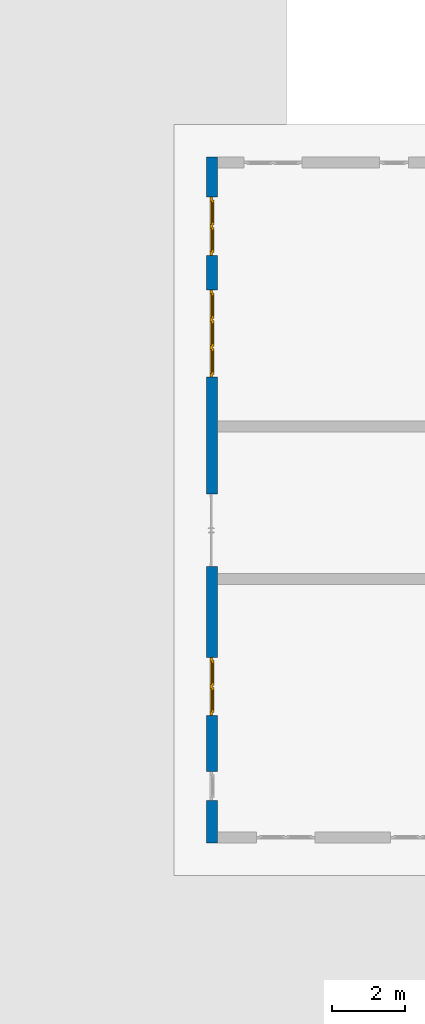
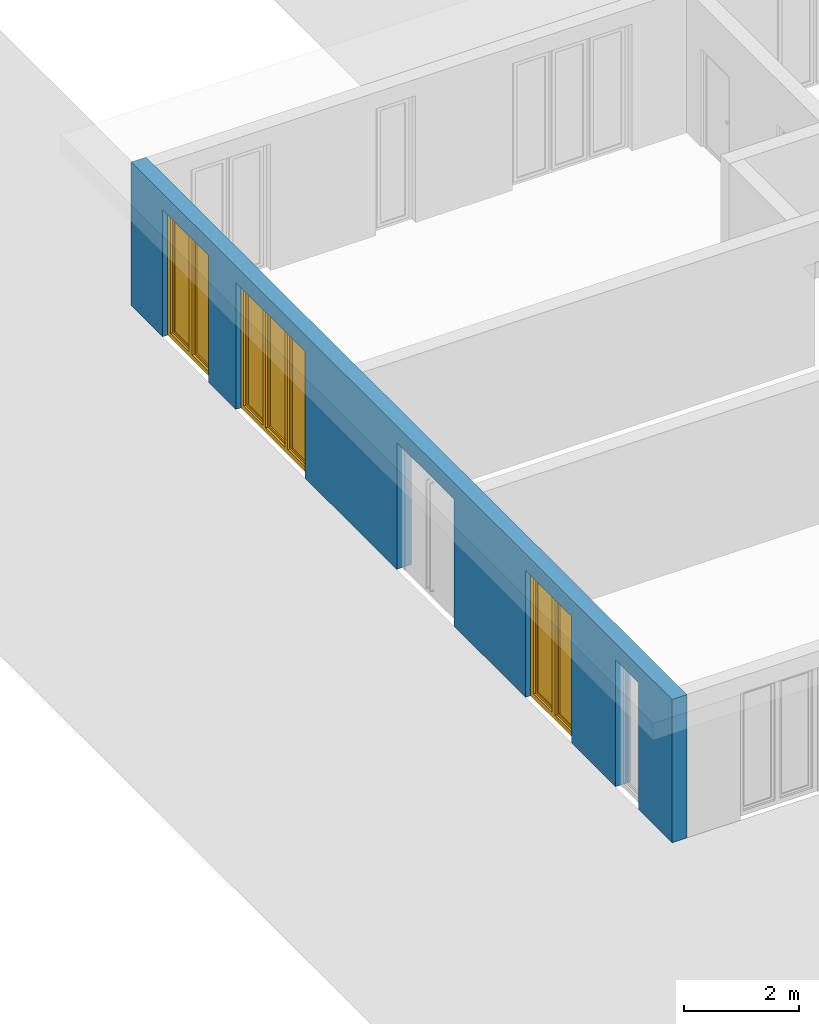
# One storey, part 9 of 23: 3 windows, 1 wall, 5 openings.
"""IFC4 building model written with IfcOpenShell, lengths in metres."""

from ifc_helpers import new_model, entity, si_unit, converted_unit, derived_unit, direction, frame, origin_with_axes, place, context, subcontext, project, spatial, polygons, source, transform, mapped, material, type_object, element, fill, save


model = new_model("IFC4")

# Units and contexts
model_context = context("Model", 3, precision=1e-05, world=origin_with_axes(), true_north=direction((0.0, 1.0)))
body_context = subcontext(model_context, "Body", "Model", "MODEL_VIEW")
ifc_project = project(units=[si_unit("LENGTHUNIT", "METRE"), si_unit("AREAUNIT", "SQUARE_METRE"), si_unit("VOLUMEUNIT", "CUBIC_METRE"), converted_unit("PLANEANGLEUNIT", "DEGREE", entity("IfcPlaneAngleMeasure", 0.0174532925199), si_unit("PLANEANGLEUNIT", "RADIAN"), dimensions=[0, 0, 0, 0, 0, 0, 0]), converted_unit("TIMEUNIT", "Year", entity("IfcTimeMeasure", 31556926.0), si_unit("TIMEUNIT", "SECOND"), dimensions=[0, 0, 1, 0, 0, 0, 0]), si_unit("MASSUNIT", "GRAM", prefix="KILO"), si_unit("THERMODYNAMICTEMPERATUREUNIT", "DEGREE_CELSIUS"), si_unit("LUMINOUSINTENSITYUNIT", "LUMEN"), si_unit("ENERGYUNIT", "JOULE", prefix="MEGA"), derived_unit("THERMALCONDUCTANCEUNIT", [(si_unit("POWERUNIT", "WATT"), 1), (si_unit("LENGTHUNIT", "METRE"), -1), (si_unit("THERMODYNAMICTEMPERATUREUNIT", "KELVIN"), -1)]), derived_unit("SPECIFICHEATCAPACITYUNIT", [(si_unit("ENERGYUNIT", "JOULE"), 1), (si_unit("MASSUNIT", "GRAM", prefix="KILO"), -1), (si_unit("THERMODYNAMICTEMPERATUREUNIT", "KELVIN"), -1)]), derived_unit("MASSDENSITYUNIT", [(si_unit("MASSUNIT", "GRAM", prefix="KILO"), 1), (si_unit("VOLUMEUNIT", "CUBIC_METRE"), -1)])], contexts=[model_context])

# Site, building, storey
site_placement = place(None, origin_with_axes())
site = spatial("IfcSite", under=ifc_project, at=site_placement, CompositionType="ELEMENT")
building_placement = place(site_placement, origin_with_axes())
building = spatial("IfcBuilding", under=site, at=building_placement, CompositionType="ELEMENT")
storey_placement = place(building_placement, origin_with_axes())
storey = spatial("IfcBuildingStorey", under=building, at=storey_placement, Name="0. Geschoss", CompositionType="ELEMENT", Elevation=0.0)

# Wall, openings, windows
ifc_material = material()
wall_type = type_object("IfcWallType", Name="300", PredefinedType="NOTDEFINED")
wall_placement = place(storey_placement, frame((-11.7421993804, -9.92881223104, 0.0), z_axis=(0.0, 0.0, 1.0), x_axis=(0.0, 1.0, 0.0)))
wall = element("IfcWall", 1, at=wall_placement, inside=storey, type_object=wall_type, material=ifc_material, Name="Wand-001", PredefinedType="NOTDEFINED", context=body_context, shape_type="Tessellation", body=[
    polygons([(7.5921181063, -0.3, 0.0), (7.5921181063, -0.3, 2.7), (9.5921181063, -0.3, 2.7), (9.5921181063, -0.3, 0.0), (12.8, -0.3, 0.0), (12.8, -0.3, 2.7), (15.2, -0.3, 2.7), (15.2, -0.3, 0.0), (16.15, -0.3, 0.0), (16.15, -0.3, 2.7), (17.75, -0.3, 2.7), (17.75, -0.3, 0.0), (18.85, -0.3, 0.0), (18.85, -0.3, 3.05), (0.0, -0.3, 3.05), (0.0, -0.3, 0.0), (1.16441876325, -0.3, 0.0), (1.16441876325, -0.3, 2.7), (1.96441876325, -0.3, 2.7), (1.96441876325, -0.3, 0.0), (3.5, -0.3, 0.0), (3.5, -0.3, 2.7), (5.1, -0.3, 2.7), (5.1, -0.3, 0.0), (7.5921181063, -0.1, 0.0), (7.5921181063, -0.1, 2.7), (9.5921181063, -0.1, 2.7), (9.5921181063, -0.1, 0.0), (9.5921181063, 0.0, 0.0), (12.8, 0.0, 0.0), (12.8, -0.1, 0.0), (12.8, -0.1, 2.7), (15.2, -0.1, 2.7), (15.2, -0.1, 0.0), (15.2, 0.0, 0.0), (16.15, 0.0, 0.0), (16.15, -0.1, 0.0), (16.15, -0.1, 2.7), (17.75, -0.1, 2.7), (17.75, -0.1, 0.0), (17.75, 0.0, 0.0), (18.85, 0.0, 0.0), (18.85, 0.0, 3.05), (0.0, 0.0, 3.05), (0.0, 0.0, 0.0), (1.16441876325, 0.0, 0.0), (1.16441876325, -0.1, 0.0), (1.16441876325, -0.1, 2.7), (1.96441876325, -0.1, 2.7), (1.96441876325, -0.1, 0.0), (1.96441876325, 0.0, 0.0), (3.5, 0.0, 0.0), (3.5, -0.1, 0.0), (3.5, -0.1, 2.7), (5.1, -0.1, 2.7), (5.1, -0.1, 0.0), (5.1, 0.0, 0.0), (7.5921181063, 0.0, 0.0), (7.5921181063, 0.0, 2.7), (9.5921181063, 0.0, 2.7), (5.1, 0.0, 2.7), (3.5, 0.0, 2.7), (1.96441876325, 0.0, 2.7), (1.16441876325, 0.0, 2.7), (17.75, 0.0, 2.7), (16.15, 0.0, 2.7), (15.2, 0.0, 2.7), (12.8, 0.0, 2.7)], [[[1, 2, 3, 4, 5, 6, 7, 8, 9, 10, 11, 12, 13, 14, 15, 16, 17, 18, 19, 20, 21, 22, 23, 24]], [[2, 1, 25, 26]], [[3, 2, 26, 27]], [[4, 3, 27, 28]], [[4, 28, 29, 30, 31, 5]], [[31, 32, 6, 5]], [[32, 33, 7, 6]], [[33, 34, 8, 7]], [[8, 34, 35, 36, 37, 9]], [[10, 9, 37, 38]], [[11, 10, 38, 39]], [[12, 11, 39, 40]], [[40, 41, 42, 13, 12]], [[14, 13, 42, 43]], [[14, 43, 44, 15]], [[44, 45, 16, 15]], [[46, 47, 17, 16, 45]], [[47, 48, 18, 17]], [[48, 49, 19, 18]], [[49, 50, 20, 19]], [[20, 50, 51, 52, 53, 21]], [[22, 21, 53, 54]], [[23, 22, 54, 55]], [[24, 23, 55, 56]], [[25, 1, 24, 56, 57, 58]], [[26, 25, 58, 59]], [[27, 26, 59, 60]], [[28, 27, 60, 29]], [[30, 29, 60, 59, 58, 57, 61, 62, 52, 51, 63, 64, 46, 45, 44, 43, 42, 41, 65, 66, 36, 35, 67, 68]], [[30, 68, 32, 31]], [[68, 67, 33, 32]], [[67, 35, 34, 33]], [[38, 37, 36, 66]], [[39, 38, 66, 65]], [[40, 39, 65, 41]], [[46, 64, 48, 47]], [[64, 63, 49, 48]], [[63, 51, 50, 49]], [[54, 53, 52, 62]], [[55, 54, 62, 61]], [[56, 55, 61, 57]]], closed=True),
])
opening_1_placement = place(wall_placement, frame((16.95, 0.0, 0.0), z_axis=(0.0, 0.0, 1.0), x_axis=(1.0, 0.0, 0.0)))
opening_1 = element("IfcOpeningElement", 2, at=opening_1_placement, cuts=wall, Name="Fenster-001", context=body_context, identifier="Reference", shape_type="Tessellation", body=[
    polygons([(-0.8, -0.1, 0.0), (-0.8, -0.1, 2.7), (-0.8, 0.000999999999999, 2.7), (-0.8, 0.000999999999999, 0.0), (-0.8, -0.301, 0.0), (-0.8, -0.301, 2.7), (0.8, -0.1, 2.7), (0.8, 0.000999999999999, 2.7), (0.8, -0.301, 2.7), (0.8, 0.000999999999999, 0.0), (0.8, -0.1, 0.0), (0.8, -0.301, 0.0)], [[[1, 2, 3, 4]], [[2, 1, 5, 6]], [[7, 8, 3, 2, 6, 9]], [[8, 10, 4, 3]], [[1, 4, 10, 11, 12, 5]], [[6, 5, 12, 9]], [[7, 11, 10, 8]], [[11, 7, 9, 12]]], closed=True),
])
opening_2_placement = place(wall_placement, frame((14.0, 0.0, 0.0), z_axis=(0.0, 0.0, 1.0), x_axis=(1.0, 0.0, 0.0)))
opening_2 = element("IfcOpeningElement", 3, at=opening_2_placement, cuts=wall, Name="Fenster-002", context=body_context, identifier="Reference", shape_type="Tessellation", body=[
    polygons([(-1.2, -0.1, 0.0), (-1.2, -0.1, 2.7), (-1.2, 0.000999999999999, 2.7), (-1.2, 0.000999999999999, 0.0), (-1.2, -0.301, 0.0), (-1.2, -0.301, 2.7), (1.2, -0.1, 2.7), (1.2, 0.000999999999999, 2.7), (1.2, -0.301, 2.7), (1.2, 0.000999999999999, 0.0), (1.2, -0.1, 0.0), (1.2, -0.301, 0.0)], [[[1, 2, 3, 4]], [[2, 1, 5, 6]], [[7, 8, 3, 2, 6, 9]], [[8, 10, 4, 3]], [[1, 4, 10, 11, 12, 5]], [[6, 5, 12, 9]], [[7, 11, 10, 8]], [[11, 7, 9, 12]]], closed=True),
])
opening_3_placement = place(wall_placement, frame((4.3, 0.0, 0.0), z_axis=(0.0, 0.0, 1.0), x_axis=(1.0, 0.0, 0.0)))
opening_3 = element("IfcOpeningElement", 4, at=opening_3_placement, cuts=wall, Name="Fenster-001", context=body_context, identifier="Reference", shape_type="Tessellation", body=[
    polygons([(-0.8, -0.1, 0.0), (-0.8, -0.1, 2.7), (-0.8, 0.000999999999999, 2.7), (-0.8, 0.000999999999999, 0.0), (-0.8, -0.301, 0.0), (-0.8, -0.301, 2.7), (0.8, -0.1, 2.7), (0.8, 0.000999999999999, 2.7), (0.8, -0.301, 2.7), (0.8, 0.000999999999999, 0.0), (0.8, -0.1, 0.0), (0.8, -0.301, 0.0)], [[[1, 2, 3, 4]], [[2, 1, 5, 6]], [[7, 8, 3, 2, 6, 9]], [[8, 10, 4, 3]], [[1, 4, 10, 11, 12, 5]], [[6, 5, 12, 9]], [[7, 11, 10, 8]], [[11, 7, 9, 12]]], closed=True),
])
opening_4_placement = place(wall_placement, frame((1.56441876325, 0.0, 0.0), z_axis=(0.0, 0.0, 1.0), x_axis=(1.0, 0.0, 0.0)))
element("IfcOpeningElement", 5, at=opening_4_placement, cuts=wall, Name="Fenster-003", context=body_context, identifier="Reference", shape_type="Tessellation", body=[
    polygons([(-0.4, -0.1, 0.0), (-0.4, -0.1, 2.7), (-0.4, 0.000999999999999, 2.7), (-0.4, 0.000999999999999, 0.0), (-0.4, -0.301, 0.0), (-0.4, -0.301, 2.7), (0.4, -0.1, 2.7), (0.4, 0.000999999999999, 2.7), (0.4, -0.301, 2.7), (0.4, 0.000999999999999, 0.0), (0.4, -0.1, 0.0), (0.4, -0.301, 0.0)], [[[1, 2, 3, 4]], [[2, 1, 5, 6]], [[7, 8, 3, 2, 6, 9]], [[8, 10, 4, 3]], [[1, 4, 10, 11, 12, 5]], [[6, 5, 12, 9]], [[7, 11, 10, 8]], [[11, 7, 9, 12]]], closed=True),
])
opening_5_placement = place(wall_placement, frame((8.5921181063, 0.0, 0.0), z_axis=(0.0, 0.0, 1.0), x_axis=(1.0, 0.0, 0.0)))
element("IfcOpeningElement", 6, at=opening_5_placement, cuts=wall, context=body_context, identifier="Reference", shape_type="Tessellation", body=[
    polygons([(-1.0, -0.1, 0.0), (-1.0, -0.1, 2.7), (-1.0, 0.000999999999999, 2.7), (-1.0, 0.000999999999999, 0.0), (-1.0, -0.301, 0.0), (-1.0, -0.301, 2.7), (1.0, -0.1, 2.7), (1.0, 0.000999999999999, 2.7), (1.0, -0.301, 2.7), (1.0, 0.000999999999999, 0.0), (1.0, -0.1, 0.0), (1.0, -0.301, 0.0)], [[[1, 2, 3, 4]], [[2, 1, 5, 6]], [[7, 8, 3, 2, 6, 9]], [[8, 10, 4, 3]], [[1, 4, 10, 11, 12, 5]], [[6, 5, 12, 9]], [[7, 11, 10, 8]], [[11, 7, 9, 12]]], closed=True),
])
window_type_1 = type_object("IfcWindowType", Name="2-1+1 26", PartitioningType="DOUBLE_PANEL_VERTICAL", PredefinedType="WINDOW")
shared_shape_1 = source(origin_with_axes(), body_context, "Body", "Tessellation", [
    polygons([(0.8, -0.07, 0.0), (0.7, -0.07, 0.1), (0.7, 0.0, 0.1), (0.8, 0.0, 0.0), (0.8, -0.07, 2.7), (0.7, -0.07, 2.6), (0.7, 0.0, 2.6), (0.8, 0.0, 2.7)], [[[1, 2, 3, 4]], [[1, 5, 6, 2]], [[2, 6, 7, 3]], [[4, 3, 7, 8]], [[5, 1, 4, 8]], [[6, 5, 8, 7]]], closed=True),
    polygons([(-0.8, -0.07, 0.0), (-0.8, -0.07, 2.7), (-0.8, 0.0, 2.7), (-0.8, 0.0, 0.0), (-0.7, -0.07, 0.1), (-0.7, -0.07, 2.6), (-0.7, 0.0, 2.6), (-0.7, 0.0, 0.1)], [[[1, 2, 3, 4]], [[1, 5, 6, 2]], [[2, 6, 7, 3]], [[4, 3, 7, 8]], [[5, 1, 4, 8]], [[6, 5, 8, 7]]], closed=True),
    polygons([(0.8, -0.07, 0.0), (-0.8, -0.07, 0.0), (-0.8, 0.0, 0.0), (0.8, 0.0, 0.0), (0.7, -0.07, 0.1), (0.05, -0.07, 0.1), (-0.05, -0.07, 0.1), (-0.7, -0.07, 0.1), (-0.7, 0.0, 0.1), (-0.05, 0.0, 0.1), (0.05, 0.0, 0.1), (0.7, 0.0, 0.1)], [[[1, 2, 3, 4]], [[1, 5, 6, 7, 8, 2]], [[2, 8, 9, 3]], [[4, 3, 9, 10, 11, 12]], [[5, 1, 4, 12]], [[6, 5, 12, 11]], [[7, 6, 11, 10]], [[8, 7, 10, 9]]], closed=True),
    polygons([(0.8, -0.07, 2.7), (0.7, -0.07, 2.6), (0.7, 0.0, 2.6), (0.8, 0.0, 2.7), (-0.8, -0.07, 2.7), (-0.7, -0.07, 2.6), (-0.05, -0.07, 2.6), (0.05, -0.07, 2.6), (0.05, 0.0, 2.6), (-0.05, 0.0, 2.6), (-0.7, 0.0, 2.6), (-0.8, 0.0, 2.7)], [[[1, 2, 3, 4]], [[1, 5, 6, 7, 8, 2]], [[2, 8, 9, 3]], [[4, 3, 9, 10, 11, 12]], [[5, 1, 4, 12]], [[6, 5, 12, 11]], [[7, 6, 11, 10]], [[8, 7, 10, 9]]], closed=True),
    polygons([(0.05, -0.07, 0.1), (-0.05, -0.07, 0.1), (-0.05, 0.0, 0.1), (0.05, 0.0, 0.1), (0.05, -0.07, 2.6), (-0.05, -0.07, 2.6), (-0.05, 0.0, 2.6), (0.05, 0.0, 2.6)], [[[1, 2, 3, 4]], [[1, 5, 6, 2]], [[2, 6, 7, 3]], [[4, 3, 7, 8]], [[5, 1, 4, 8]], [[6, 5, 8, 7]]], closed=True),
    polygons([(0.72, 0.0, 0.08), (0.65, 0.0, 0.15), (0.65, 0.03, 0.15), (0.72, 0.03, 0.08), (0.72, 0.0, 2.62), (0.65, 0.0, 2.55), (0.65, 0.03, 2.55), (0.72, 0.03, 2.62)], [[[1, 2, 3, 4]], [[1, 5, 6, 2]], [[2, 6, 7, 3]], [[4, 3, 7, 8]], [[5, 1, 4, 8]], [[6, 5, 8, 7]]], closed=True),
    polygons([(0.03, 0.0, 0.08), (0.03, 0.03, 0.08), (0.1, 0.03, 0.15), (0.1, 0.0, 0.15), (0.03, 0.0, 2.62), (0.03, 0.03, 2.62), (0.1, 0.03, 2.55), (0.1, 0.0, 2.55)], [[[1, 2, 3, 4]], [[5, 6, 2, 1]], [[2, 6, 7, 3]], [[4, 3, 7, 8]], [[1, 4, 8, 5]], [[8, 7, 6, 5]]], closed=True),
    polygons([(0.72, 0.0, 0.08), (0.03, 0.0, 0.08), (0.03, 0.03, 0.08), (0.72, 0.03, 0.08), (0.65, 0.0, 0.15), (0.1, 0.0, 0.15), (0.1, 0.03, 0.15), (0.65, 0.03, 0.15)], [[[1, 2, 3, 4]], [[1, 5, 6, 2]], [[2, 6, 7, 3]], [[4, 3, 7, 8]], [[5, 1, 4, 8]], [[6, 5, 8, 7]]], closed=True),
    polygons([(0.72, 0.0, 2.62), (0.72, 0.03, 2.62), (0.03, 0.03, 2.62), (0.03, 0.0, 2.62), (0.65, 0.0, 2.55), (0.65, 0.03, 2.55), (0.1, 0.03, 2.55), (0.1, 0.0, 2.55)], [[[1, 2, 3, 4]], [[5, 6, 2, 1]], [[2, 6, 7, 3]], [[4, 3, 7, 8]], [[1, 4, 8, 5]], [[8, 7, 6, 5]]], closed=True),
    polygons([(0.7, -0.03, 0.1), (0.65, -0.03, 0.15), (0.65, 0.0, 0.15), (0.7, 0.0, 0.1), (0.7, -0.03, 2.6), (0.65, -0.03, 2.55), (0.65, 0.0, 2.55), (0.7, 0.0, 2.6)], [[[1, 2, 3, 4]], [[1, 5, 6, 2]], [[2, 6, 7, 3]], [[4, 3, 7, 8]], [[5, 1, 4, 8]], [[6, 5, 8, 7]]], closed=True),
    polygons([(0.05, -0.03, 0.1), (0.05, 0.0, 0.1), (0.1, 0.0, 0.15), (0.1, -0.03, 0.15), (0.05, -0.03, 2.6), (0.05, 0.0, 2.6), (0.1, 0.0, 2.55), (0.1, -0.03, 2.55)], [[[1, 2, 3, 4]], [[5, 6, 2, 1]], [[2, 6, 7, 3]], [[4, 3, 7, 8]], [[1, 4, 8, 5]], [[8, 7, 6, 5]]], closed=True),
    polygons([(0.7, -0.03, 0.1), (0.05, -0.03, 0.1), (0.05, 0.0, 0.1), (0.7, 0.0, 0.1), (0.65, -0.03, 0.15), (0.1, -0.03, 0.15), (0.1, 0.0, 0.15), (0.65, 0.0, 0.15)], [[[1, 2, 3, 4]], [[1, 5, 6, 2]], [[2, 6, 7, 3]], [[4, 3, 7, 8]], [[5, 1, 4, 8]], [[6, 5, 8, 7]]], closed=True),
    polygons([(0.7, -0.03, 2.6), (0.7, 0.0, 2.6), (0.05, 0.0, 2.6), (0.05, -0.03, 2.6), (0.65, -0.03, 2.55), (0.65, 0.0, 2.55), (0.1, 0.0, 2.55), (0.1, -0.03, 2.55)], [[[1, 2, 3, 4]], [[5, 6, 2, 1]], [[2, 6, 7, 3]], [[4, 3, 7, 8]], [[1, 4, 8, 5]], [[8, 7, 6, 5]]], closed=True),
    polygons([(0.65, -0.005, 0.15), (0.1, -0.005, 0.15), (0.1, 0.005, 0.15), (0.65, 0.005, 0.15), (0.65, -0.005, 2.55), (0.1, -0.005, 2.55), (0.1, 0.005, 2.55), (0.65, 0.005, 2.55)], [[[1, 2, 3, 4]], [[1, 5, 6, 2]], [[2, 6, 7, 3]], [[4, 3, 7, 8]], [[5, 1, 4, 8]], [[6, 5, 8, 7]]], closed=True),
    polygons([(-0.03, 0.0, 0.08), (-0.1, 0.0, 0.15), (-0.1, 0.03, 0.15), (-0.03, 0.03, 0.08), (-0.03, 0.0, 2.62), (-0.1, 0.0, 2.55), (-0.1, 0.03, 2.55), (-0.03, 0.03, 2.62)], [[[1, 2, 3, 4]], [[1, 5, 6, 2]], [[2, 6, 7, 3]], [[4, 3, 7, 8]], [[5, 1, 4, 8]], [[6, 5, 8, 7]]], closed=True),
    polygons([(-0.72, 0.0, 0.08), (-0.72, 0.03, 0.08), (-0.65, 0.03, 0.15), (-0.65, 0.0, 0.15), (-0.72, 0.0, 2.62), (-0.72, 0.03, 2.62), (-0.65, 0.03, 2.55), (-0.65, 0.0, 2.55)], [[[1, 2, 3, 4]], [[5, 6, 2, 1]], [[2, 6, 7, 3]], [[4, 3, 7, 8]], [[1, 4, 8, 5]], [[8, 7, 6, 5]]], closed=True),
    polygons([(-0.03, 0.0, 0.08), (-0.72, 0.0, 0.08), (-0.72, 0.03, 0.08), (-0.03, 0.03, 0.08), (-0.1, 0.0, 0.15), (-0.65, 0.0, 0.15), (-0.65, 0.03, 0.15), (-0.1, 0.03, 0.15)], [[[1, 2, 3, 4]], [[1, 5, 6, 2]], [[2, 6, 7, 3]], [[4, 3, 7, 8]], [[5, 1, 4, 8]], [[6, 5, 8, 7]]], closed=True),
    polygons([(-0.03, 0.0, 2.62), (-0.03, 0.03, 2.62), (-0.72, 0.03, 2.62), (-0.72, 0.0, 2.62), (-0.1, 0.0, 2.55), (-0.1, 0.03, 2.55), (-0.65, 0.03, 2.55), (-0.65, 0.0, 2.55)], [[[1, 2, 3, 4]], [[5, 6, 2, 1]], [[2, 6, 7, 3]], [[4, 3, 7, 8]], [[1, 4, 8, 5]], [[8, 7, 6, 5]]], closed=True),
    polygons([(-0.05, -0.03, 0.1), (-0.1, -0.03, 0.15), (-0.1, 0.0, 0.15), (-0.05, 0.0, 0.1), (-0.05, -0.03, 2.6), (-0.1, -0.03, 2.55), (-0.1, 0.0, 2.55), (-0.05, 0.0, 2.6)], [[[1, 2, 3, 4]], [[1, 5, 6, 2]], [[2, 6, 7, 3]], [[4, 3, 7, 8]], [[5, 1, 4, 8]], [[6, 5, 8, 7]]], closed=True),
    polygons([(-0.7, -0.03, 0.1), (-0.7, 0.0, 0.1), (-0.65, 0.0, 0.15), (-0.65, -0.03, 0.15), (-0.7, -0.03, 2.6), (-0.7, 0.0, 2.6), (-0.65, 0.0, 2.55), (-0.65, -0.03, 2.55)], [[[1, 2, 3, 4]], [[5, 6, 2, 1]], [[2, 6, 7, 3]], [[4, 3, 7, 8]], [[1, 4, 8, 5]], [[8, 7, 6, 5]]], closed=True),
    polygons([(-0.05, -0.03, 0.1), (-0.7, -0.03, 0.1), (-0.7, 0.0, 0.1), (-0.05, 0.0, 0.1), (-0.1, -0.03, 0.15), (-0.65, -0.03, 0.15), (-0.65, 0.0, 0.15), (-0.1, 0.0, 0.15)], [[[1, 2, 3, 4]], [[1, 5, 6, 2]], [[2, 6, 7, 3]], [[4, 3, 7, 8]], [[5, 1, 4, 8]], [[6, 5, 8, 7]]], closed=True),
    polygons([(-0.05, -0.03, 2.6), (-0.05, 0.0, 2.6), (-0.7, 0.0, 2.6), (-0.7, -0.03, 2.6), (-0.1, -0.03, 2.55), (-0.1, 0.0, 2.55), (-0.65, 0.0, 2.55), (-0.65, -0.03, 2.55)], [[[1, 2, 3, 4]], [[5, 6, 2, 1]], [[2, 6, 7, 3]], [[4, 3, 7, 8]], [[1, 4, 8, 5]], [[8, 7, 6, 5]]], closed=True),
    polygons([(-0.1, -0.005, 0.15), (-0.65, -0.005, 0.15), (-0.65, 0.005, 0.15), (-0.1, 0.005, 0.15), (-0.1, -0.005, 2.55), (-0.65, -0.005, 2.55), (-0.65, 0.005, 2.55), (-0.1, 0.005, 2.55)], [[[1, 2, 3, 4]], [[1, 5, 6, 2]], [[2, 6, 7, 3]], [[4, 3, 7, 8]], [[5, 1, 4, 8]], [[6, 5, 8, 7]]], closed=True),
])
window_1_placement = place(opening_1_placement, frame((0.8, 0.0, 0.0), z_axis=(0.0, 0.0, 1.0), x_axis=(-1.0, 0.0, 0.0)))
window_1 = element("IfcWindow", 7, at=window_1_placement, inside=storey, type_object=window_type_1, Name="Fenster-001", OverallHeight=2.7, OverallWidth=1.6, PredefinedType="WINDOW", context=body_context, shape_type="MappedRepresentation", body=[
    mapped(shared_shape_1, transform((0.8, 0.17, 0.0))),
])
fill(opening_1, window_1)
window_2_placement = place(opening_3_placement, frame((0.8, 0.0, 0.0), z_axis=(0.0, 0.0, 1.0), x_axis=(-1.0, 0.0, 0.0)))
window_2 = element("IfcWindow", 8, at=window_2_placement, inside=storey, type_object=window_type_1, Name="Fenster-001", OverallHeight=2.7, OverallWidth=1.6, PredefinedType="WINDOW", context=body_context, shape_type="MappedRepresentation", body=[
    mapped(shared_shape_1, transform((0.8, 0.17, 0.0))),
])
fill(opening_3, window_2)
window_type_2 = type_object("IfcWindowType", Name="3-1+1+1 26", PartitioningType="TRIPLE_PANEL_VERTICAL", PredefinedType="WINDOW")
shared_shape_2 = source(origin_with_axes(), body_context, "Body", "Tessellation", [
    polygons([(1.2, -0.07, 0.0), (1.1, -0.07, 0.1), (1.1, 0.0, 0.1), (1.2, 0.0, 0.0), (1.2, -0.07, 2.7), (1.1, -0.07, 2.6), (1.1, 0.0, 2.6), (1.2, 0.0, 2.7)], [[[1, 2, 3, 4]], [[1, 5, 6, 2]], [[2, 6, 7, 3]], [[4, 3, 7, 8]], [[5, 1, 4, 8]], [[6, 5, 8, 7]]], closed=True),
    polygons([(-1.2, -0.07, 0.0), (-1.2, -0.07, 2.7), (-1.2, 0.0, 2.7), (-1.2, 0.0, 0.0), (-1.1, -0.07, 0.1), (-1.1, -0.07, 2.6), (-1.1, 0.0, 2.6), (-1.1, 0.0, 0.1)], [[[1, 2, 3, 4]], [[1, 5, 6, 2]], [[2, 6, 7, 3]], [[4, 3, 7, 8]], [[5, 1, 4, 8]], [[6, 5, 8, 7]]], closed=True),
    polygons([(1.2, -0.07, 0.0), (-1.2, -0.07, 0.0), (-1.2, 0.0, 0.0), (1.2, 0.0, 0.0), (1.1, -0.07, 0.1), (0.433333333333, -0.07, 0.1), (0.333333333333, -0.07, 0.1), (-0.333333333333, -0.07, 0.1), (-0.433333333333, -0.07, 0.1), (-1.1, -0.07, 0.1), (-1.1, 0.0, 0.1), (-0.433333333333, 0.0, 0.1), (-0.333333333333, 0.0, 0.1), (0.333333333333, 0.0, 0.1), (0.433333333333, 0.0, 0.1), (1.1, 0.0, 0.1)], [[[1, 2, 3, 4]], [[1, 5, 6, 7, 8, 9, 10, 2]], [[2, 10, 11, 3]], [[4, 3, 11, 12, 13, 14, 15, 16]], [[5, 1, 4, 16]], [[6, 5, 16, 15]], [[7, 6, 15, 14]], [[8, 7, 14, 13]], [[9, 8, 13, 12]], [[10, 9, 12, 11]]], closed=True),
    polygons([(1.2, -0.07, 2.7), (1.1, -0.07, 2.6), (1.1, 0.0, 2.6), (1.2, 0.0, 2.7), (-1.2, -0.07, 2.7), (-1.1, -0.07, 2.6), (-0.433333333333, -0.07, 2.6), (-0.333333333333, -0.07, 2.6), (0.333333333333, -0.07, 2.6), (0.433333333333, -0.07, 2.6), (0.433333333333, 0.0, 2.6), (0.333333333333, 0.0, 2.6), (-0.333333333333, 0.0, 2.6), (-0.433333333333, 0.0, 2.6), (-1.1, 0.0, 2.6), (-1.2, 0.0, 2.7)], [[[1, 2, 3, 4]], [[1, 5, 6, 7, 8, 9, 10, 2]], [[2, 10, 11, 3]], [[4, 3, 11, 12, 13, 14, 15, 16]], [[5, 1, 4, 16]], [[6, 5, 16, 15]], [[7, 6, 15, 14]], [[8, 7, 14, 13]], [[9, 8, 13, 12]], [[10, 9, 12, 11]]], closed=True),
    polygons([(-0.333333333333, -0.07, 0.1), (-0.433333333333, -0.07, 0.1), (-0.433333333333, 0.0, 0.1), (-0.333333333333, 0.0, 0.1), (-0.333333333333, -0.07, 2.6), (-0.433333333333, -0.07, 2.6), (-0.433333333333, 0.0, 2.6), (-0.333333333333, 0.0, 2.6)], [[[1, 2, 3, 4]], [[1, 5, 6, 2]], [[2, 6, 7, 3]], [[4, 3, 7, 8]], [[5, 1, 4, 8]], [[6, 5, 8, 7]]], closed=True),
    polygons([(0.433333333333, -0.07, 0.1), (0.333333333333, -0.07, 0.1), (0.333333333333, 0.0, 0.1), (0.433333333333, 0.0, 0.1), (0.433333333333, -0.07, 2.6), (0.333333333333, -0.07, 2.6), (0.333333333333, 0.0, 2.6), (0.433333333333, 0.0, 2.6)], [[[1, 2, 3, 4]], [[1, 5, 6, 2]], [[2, 6, 7, 3]], [[4, 3, 7, 8]], [[5, 1, 4, 8]], [[6, 5, 8, 7]]], closed=True),
    polygons([(1.12, 0.0, 0.08), (1.05, 0.0, 0.15), (1.05, 0.03, 0.15), (1.12, 0.03, 0.08), (1.12, 0.0, 2.62), (1.05, 0.0, 2.55), (1.05, 0.03, 2.55), (1.12, 0.03, 2.62)], [[[1, 2, 3, 4]], [[1, 5, 6, 2]], [[2, 6, 7, 3]], [[4, 3, 7, 8]], [[5, 1, 4, 8]], [[6, 5, 8, 7]]], closed=True),
    polygons([(0.413333333333, 0.0, 0.08), (0.413333333333, 0.03, 0.08), (0.483333333333, 0.03, 0.15), (0.483333333333, 0.0, 0.15), (0.413333333333, 0.0, 2.62), (0.413333333333, 0.03, 2.62), (0.483333333333, 0.03, 2.55), (0.483333333333, 0.0, 2.55)], [[[1, 2, 3, 4]], [[5, 6, 2, 1]], [[2, 6, 7, 3]], [[4, 3, 7, 8]], [[1, 4, 8, 5]], [[8, 7, 6, 5]]], closed=True),
    polygons([(1.12, 0.0, 0.08), (0.413333333333, 0.0, 0.08), (0.413333333333, 0.03, 0.08), (1.12, 0.03, 0.08), (1.05, 0.0, 0.15), (0.483333333333, 0.0, 0.15), (0.483333333333, 0.03, 0.15), (1.05, 0.03, 0.15)], [[[1, 2, 3, 4]], [[1, 5, 6, 2]], [[2, 6, 7, 3]], [[4, 3, 7, 8]], [[5, 1, 4, 8]], [[6, 5, 8, 7]]], closed=True),
    polygons([(1.12, 0.0, 2.62), (1.12, 0.03, 2.62), (0.413333333333, 0.03, 2.62), (0.413333333333, 0.0, 2.62), (1.05, 0.0, 2.55), (1.05, 0.03, 2.55), (0.483333333333, 0.03, 2.55), (0.483333333333, 0.0, 2.55)], [[[1, 2, 3, 4]], [[5, 6, 2, 1]], [[2, 6, 7, 3]], [[4, 3, 7, 8]], [[1, 4, 8, 5]], [[8, 7, 6, 5]]], closed=True),
    polygons([(1.1, -0.03, 0.1), (1.05, -0.03, 0.15), (1.05, 0.0, 0.15), (1.1, 0.0, 0.1), (1.1, -0.03, 2.6), (1.05, -0.03, 2.55), (1.05, 0.0, 2.55), (1.1, 0.0, 2.6)], [[[1, 2, 3, 4]], [[1, 5, 6, 2]], [[2, 6, 7, 3]], [[4, 3, 7, 8]], [[5, 1, 4, 8]], [[6, 5, 8, 7]]], closed=True),
    polygons([(0.433333333333, -0.03, 0.1), (0.433333333333, 0.0, 0.1), (0.483333333333, 0.0, 0.15), (0.483333333333, -0.03, 0.15), (0.433333333333, -0.03, 2.6), (0.433333333333, 0.0, 2.6), (0.483333333333, 0.0, 2.55), (0.483333333333, -0.03, 2.55)], [[[1, 2, 3, 4]], [[5, 6, 2, 1]], [[2, 6, 7, 3]], [[4, 3, 7, 8]], [[1, 4, 8, 5]], [[8, 7, 6, 5]]], closed=True),
    polygons([(1.1, -0.03, 0.1), (0.433333333333, -0.03, 0.1), (0.433333333333, 0.0, 0.1), (1.1, 0.0, 0.1), (1.05, -0.03, 0.15), (0.483333333333, -0.03, 0.15), (0.483333333333, 0.0, 0.15), (1.05, 0.0, 0.15)], [[[1, 2, 3, 4]], [[1, 5, 6, 2]], [[2, 6, 7, 3]], [[4, 3, 7, 8]], [[5, 1, 4, 8]], [[6, 5, 8, 7]]], closed=True),
    polygons([(1.1, -0.03, 2.6), (1.1, 0.0, 2.6), (0.433333333333, 0.0, 2.6), (0.433333333333, -0.03, 2.6), (1.05, -0.03, 2.55), (1.05, 0.0, 2.55), (0.483333333333, 0.0, 2.55), (0.483333333333, -0.03, 2.55)], [[[1, 2, 3, 4]], [[5, 6, 2, 1]], [[2, 6, 7, 3]], [[4, 3, 7, 8]], [[1, 4, 8, 5]], [[8, 7, 6, 5]]], closed=True),
    polygons([(1.05, -0.005, 0.15), (0.483333333333, -0.005, 0.15), (0.483333333333, 0.005, 0.15), (1.05, 0.005, 0.15), (1.05, -0.005, 2.55), (0.483333333333, -0.005, 2.55), (0.483333333333, 0.005, 2.55), (1.05, 0.005, 2.55)], [[[1, 2, 3, 4]], [[1, 5, 6, 2]], [[2, 6, 7, 3]], [[4, 3, 7, 8]], [[5, 1, 4, 8]], [[6, 5, 8, 7]]], closed=True),
    polygons([(0.353333333333, 0.0, 0.08), (0.283333333333, 0.0, 0.15), (0.283333333333, 0.03, 0.15), (0.353333333333, 0.03, 0.08), (0.353333333333, 0.0, 2.62), (0.283333333333, 0.0, 2.55), (0.283333333333, 0.03, 2.55), (0.353333333333, 0.03, 2.62)], [[[1, 2, 3, 4]], [[1, 5, 6, 2]], [[2, 6, 7, 3]], [[4, 3, 7, 8]], [[5, 1, 4, 8]], [[6, 5, 8, 7]]], closed=True),
    polygons([(-0.353333333333, 0.0, 0.08), (-0.353333333333, 0.03, 0.08), (-0.283333333333, 0.03, 0.15), (-0.283333333333, 0.0, 0.15), (-0.353333333333, 0.0, 2.62), (-0.353333333333, 0.03, 2.62), (-0.283333333333, 0.03, 2.55), (-0.283333333333, 0.0, 2.55)], [[[1, 2, 3, 4]], [[5, 6, 2, 1]], [[2, 6, 7, 3]], [[4, 3, 7, 8]], [[1, 4, 8, 5]], [[8, 7, 6, 5]]], closed=True),
    polygons([(0.353333333333, 0.0, 0.08), (-0.353333333333, 0.0, 0.08), (-0.353333333333, 0.03, 0.08), (0.353333333333, 0.03, 0.08), (0.283333333333, 0.0, 0.15), (-0.283333333333, 0.0, 0.15), (-0.283333333333, 0.03, 0.15), (0.283333333333, 0.03, 0.15)], [[[1, 2, 3, 4]], [[1, 5, 6, 2]], [[2, 6, 7, 3]], [[4, 3, 7, 8]], [[5, 1, 4, 8]], [[6, 5, 8, 7]]], closed=True),
    polygons([(0.353333333333, 0.0, 2.62), (0.353333333333, 0.03, 2.62), (-0.353333333333, 0.03, 2.62), (-0.353333333333, 0.0, 2.62), (0.283333333333, 0.0, 2.55), (0.283333333333, 0.03, 2.55), (-0.283333333333, 0.03, 2.55), (-0.283333333333, 0.0, 2.55)], [[[1, 2, 3, 4]], [[5, 6, 2, 1]], [[2, 6, 7, 3]], [[4, 3, 7, 8]], [[1, 4, 8, 5]], [[8, 7, 6, 5]]], closed=True),
    polygons([(0.333333333333, -0.03, 0.1), (0.283333333333, -0.03, 0.15), (0.283333333333, 0.0, 0.15), (0.333333333333, 0.0, 0.1), (0.333333333333, -0.03, 2.6), (0.283333333333, -0.03, 2.55), (0.283333333333, 0.0, 2.55), (0.333333333333, 0.0, 2.6)], [[[1, 2, 3, 4]], [[1, 5, 6, 2]], [[2, 6, 7, 3]], [[4, 3, 7, 8]], [[5, 1, 4, 8]], [[6, 5, 8, 7]]], closed=True),
    polygons([(-0.333333333333, -0.03, 0.1), (-0.333333333333, 0.0, 0.1), (-0.283333333333, 0.0, 0.15), (-0.283333333333, -0.03, 0.15), (-0.333333333333, -0.03, 2.6), (-0.333333333333, 0.0, 2.6), (-0.283333333333, 0.0, 2.55), (-0.283333333333, -0.03, 2.55)], [[[1, 2, 3, 4]], [[5, 6, 2, 1]], [[2, 6, 7, 3]], [[4, 3, 7, 8]], [[1, 4, 8, 5]], [[8, 7, 6, 5]]], closed=True),
    polygons([(0.333333333333, -0.03, 0.1), (-0.333333333333, -0.03, 0.1), (-0.333333333333, 0.0, 0.1), (0.333333333333, 0.0, 0.1), (0.283333333333, -0.03, 0.15), (-0.283333333333, -0.03, 0.15), (-0.283333333333, 0.0, 0.15), (0.283333333333, 0.0, 0.15)], [[[1, 2, 3, 4]], [[1, 5, 6, 2]], [[2, 6, 7, 3]], [[4, 3, 7, 8]], [[5, 1, 4, 8]], [[6, 5, 8, 7]]], closed=True),
    polygons([(0.333333333333, -0.03, 2.6), (0.333333333333, 0.0, 2.6), (-0.333333333333, 0.0, 2.6), (-0.333333333333, -0.03, 2.6), (0.283333333333, -0.03, 2.55), (0.283333333333, 0.0, 2.55), (-0.283333333333, 0.0, 2.55), (-0.283333333333, -0.03, 2.55)], [[[1, 2, 3, 4]], [[5, 6, 2, 1]], [[2, 6, 7, 3]], [[4, 3, 7, 8]], [[1, 4, 8, 5]], [[8, 7, 6, 5]]], closed=True),
    polygons([(0.283333333333, -0.005, 0.15), (-0.283333333333, -0.005, 0.15), (-0.283333333333, 0.005, 0.15), (0.283333333333, 0.005, 0.15), (0.283333333333, -0.005, 2.55), (-0.283333333333, -0.005, 2.55), (-0.283333333333, 0.005, 2.55), (0.283333333333, 0.005, 2.55)], [[[1, 2, 3, 4]], [[1, 5, 6, 2]], [[2, 6, 7, 3]], [[4, 3, 7, 8]], [[5, 1, 4, 8]], [[6, 5, 8, 7]]], closed=True),
    polygons([(-0.413333333333, 0.0, 0.08), (-0.483333333333, 0.0, 0.15), (-0.483333333333, 0.03, 0.15), (-0.413333333333, 0.03, 0.08), (-0.413333333333, 0.0, 2.62), (-0.483333333333, 0.0, 2.55), (-0.483333333333, 0.03, 2.55), (-0.413333333333, 0.03, 2.62)], [[[1, 2, 3, 4]], [[1, 5, 6, 2]], [[2, 6, 7, 3]], [[4, 3, 7, 8]], [[5, 1, 4, 8]], [[6, 5, 8, 7]]], closed=True),
    polygons([(-1.12, 0.0, 0.08), (-1.12, 0.03, 0.08), (-1.05, 0.03, 0.15), (-1.05, 0.0, 0.15), (-1.12, 0.0, 2.62), (-1.12, 0.03, 2.62), (-1.05, 0.03, 2.55), (-1.05, 0.0, 2.55)], [[[1, 2, 3, 4]], [[5, 6, 2, 1]], [[2, 6, 7, 3]], [[4, 3, 7, 8]], [[1, 4, 8, 5]], [[8, 7, 6, 5]]], closed=True),
    polygons([(-0.413333333333, 0.0, 0.08), (-1.12, 0.0, 0.08), (-1.12, 0.03, 0.08), (-0.413333333333, 0.03, 0.08), (-0.483333333333, 0.0, 0.15), (-1.05, 0.0, 0.15), (-1.05, 0.03, 0.15), (-0.483333333333, 0.03, 0.15)], [[[1, 2, 3, 4]], [[1, 5, 6, 2]], [[2, 6, 7, 3]], [[4, 3, 7, 8]], [[5, 1, 4, 8]], [[6, 5, 8, 7]]], closed=True),
    polygons([(-0.413333333333, 0.0, 2.62), (-0.413333333333, 0.03, 2.62), (-1.12, 0.03, 2.62), (-1.12, 0.0, 2.62), (-0.483333333333, 0.0, 2.55), (-0.483333333333, 0.03, 2.55), (-1.05, 0.03, 2.55), (-1.05, 0.0, 2.55)], [[[1, 2, 3, 4]], [[5, 6, 2, 1]], [[2, 6, 7, 3]], [[4, 3, 7, 8]], [[1, 4, 8, 5]], [[8, 7, 6, 5]]], closed=True),
    polygons([(-0.433333333333, -0.03, 0.1), (-0.483333333333, -0.03, 0.15), (-0.483333333333, 0.0, 0.15), (-0.433333333333, 0.0, 0.1), (-0.433333333333, -0.03, 2.6), (-0.483333333333, -0.03, 2.55), (-0.483333333333, 0.0, 2.55), (-0.433333333333, 0.0, 2.6)], [[[1, 2, 3, 4]], [[1, 5, 6, 2]], [[2, 6, 7, 3]], [[4, 3, 7, 8]], [[5, 1, 4, 8]], [[6, 5, 8, 7]]], closed=True),
    polygons([(-1.1, -0.03, 0.1), (-1.1, 0.0, 0.1), (-1.05, 0.0, 0.15), (-1.05, -0.03, 0.15), (-1.1, -0.03, 2.6), (-1.1, 0.0, 2.6), (-1.05, 0.0, 2.55), (-1.05, -0.03, 2.55)], [[[1, 2, 3, 4]], [[5, 6, 2, 1]], [[2, 6, 7, 3]], [[4, 3, 7, 8]], [[1, 4, 8, 5]], [[8, 7, 6, 5]]], closed=True),
    polygons([(-0.433333333333, -0.03, 0.1), (-1.1, -0.03, 0.1), (-1.1, 0.0, 0.1), (-0.433333333333, 0.0, 0.1), (-0.483333333333, -0.03, 0.15), (-1.05, -0.03, 0.15), (-1.05, 0.0, 0.15), (-0.483333333333, 0.0, 0.15)], [[[1, 2, 3, 4]], [[1, 5, 6, 2]], [[2, 6, 7, 3]], [[4, 3, 7, 8]], [[5, 1, 4, 8]], [[6, 5, 8, 7]]], closed=True),
    polygons([(-0.433333333333, -0.03, 2.6), (-0.433333333333, 0.0, 2.6), (-1.1, 0.0, 2.6), (-1.1, -0.03, 2.6), (-0.483333333333, -0.03, 2.55), (-0.483333333333, 0.0, 2.55), (-1.05, 0.0, 2.55), (-1.05, -0.03, 2.55)], [[[1, 2, 3, 4]], [[5, 6, 2, 1]], [[2, 6, 7, 3]], [[4, 3, 7, 8]], [[1, 4, 8, 5]], [[8, 7, 6, 5]]], closed=True),
    polygons([(-0.483333333333, -0.005, 0.15), (-1.05, -0.005, 0.15), (-1.05, 0.005, 0.15), (-0.483333333333, 0.005, 0.15), (-0.483333333333, -0.005, 2.55), (-1.05, -0.005, 2.55), (-1.05, 0.005, 2.55), (-0.483333333333, 0.005, 2.55)], [[[1, 2, 3, 4]], [[1, 5, 6, 2]], [[2, 6, 7, 3]], [[4, 3, 7, 8]], [[5, 1, 4, 8]], [[6, 5, 8, 7]]], closed=True),
])
window_3_placement = place(opening_2_placement, frame((1.2, 0.0, 0.0), z_axis=(0.0, 0.0, 1.0), x_axis=(-1.0, 0.0, 0.0)))
window_3 = element("IfcWindow", 9, at=window_3_placement, inside=storey, type_object=window_type_2, Name="Fenster-002", OverallHeight=2.7, OverallWidth=2.4, PredefinedType="WINDOW", context=body_context, shape_type="MappedRepresentation", body=[
    mapped(shared_shape_2, transform((1.2, 0.17, 0.0))),
])
fill(opening_2, window_3)

save(model, "model.ifc")
